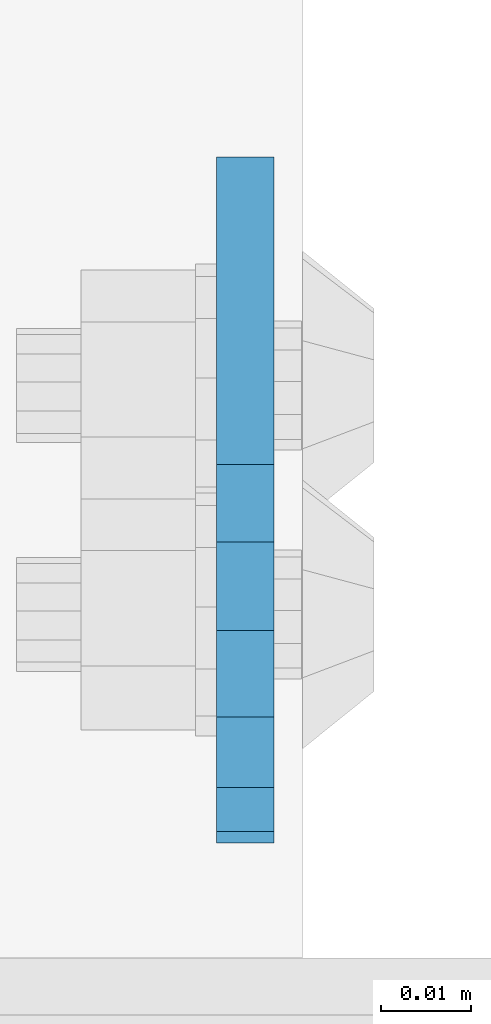
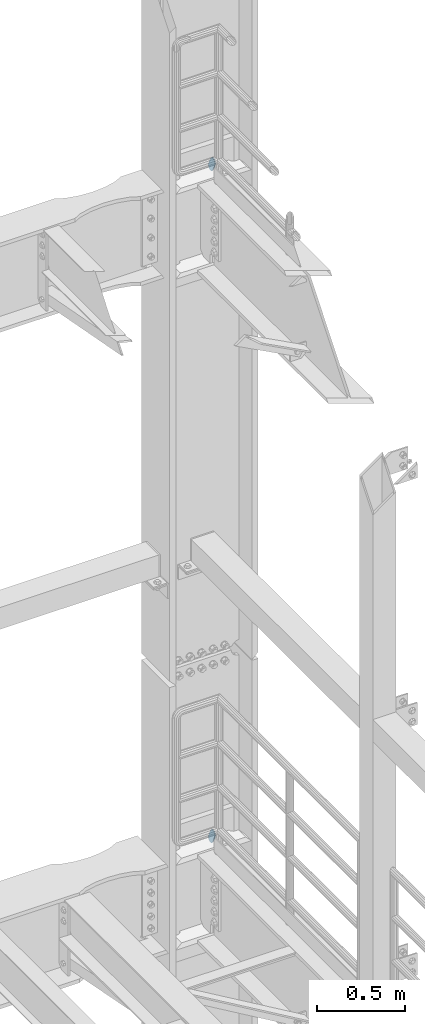
# One storey, part 1836 of 1876: 2 plates, 2 elements without a shape of their own.
"""IFC2X3 building model written with IfcOpenShell, lengths in millimetres."""

from ifc_helpers import new_model, si_unit, frame, origin_with_axes, place, context, subcontext, project, spatial, faceted_brep, material, type_object, element, aggregate, save


model = new_model("IFC2X3")

# Units and contexts
model_context = context("Model", 3, precision=1e-05, world=origin_with_axes())
body_context = subcontext(model_context, "Body", "Model", "MODEL_VIEW")
ifc_project = project(units=[si_unit("LENGTHUNIT", "METRE", prefix="MILLI"), si_unit("AREAUNIT", "SQUARE_METRE"), si_unit("VOLUMEUNIT", "CUBIC_METRE"), si_unit("MASSUNIT", "GRAM", prefix="KILO"), si_unit("TIMEUNIT", "SECOND"), si_unit("PLANEANGLEUNIT", "RADIAN"), si_unit("SOLIDANGLEUNIT", "STERADIAN"), si_unit("THERMODYNAMICTEMPERATUREUNIT", "DEGREE_CELSIUS"), si_unit("LUMINOUSINTENSITYUNIT", "LUMEN")], contexts=[model_context])

# Site, building, storey
site_placement = place(None, origin_with_axes())
site = spatial("IfcSite", under=ifc_project, at=site_placement, CompositionType="ELEMENT")
building_placement = place(site_placement, origin_with_axes())
building = spatial("IfcBuilding", under=site, at=building_placement, Name="Undefined", CompositionType="ELEMENT")
storey_placement = place(building_placement, origin_with_axes())
storey = spatial("IfcBuildingStorey", under=building, at=storey_placement, Name="Undefined", CompositionType="ELEMENT", Elevation=0.0)

# Assembly, plate
assembly_1_placement = place(storey_placement, origin_with_axes())
assembly_1 = element("IfcElementAssembly", 1, at=assembly_1_placement, inside=storey, Name="PLATE", AssemblyPlace="NOTDEFINED", PredefinedType="RIGID_FRAME")
ifc_material = material(Name="STEEL/A36")
plate_type = type_object("IfcPlateType", PredefinedType="NOTDEFINED")
plate_1_placement = place(assembly_1_placement, frame((7905.73879597858, 14070.2592249372, 17725.1776774809), z_axis=(0.0, -0.894427191199917, -0.447213595099956), x_axis=(0.0, 0.447213595099955, -0.894427191199917)))
plate_1 = element("IfcPlate", 2, at=plate_1_placement, type_object=plate_type, material=ifc_material, Name="PLATE", context=body_context, shape_type="Brep", body=[
    faceted_brep([(-8.59611645864788e-07, -3.17499999999654, 25.3999987589127), (1.93345873884391, -3.17499999999382, 35.1201580589886), (1.93345873884391, 3.17500000000564, 35.1201580589886), (-8.59611645864788e-07, 3.17500000000382, 25.3999987589132), (7.43948648259902, -3.17499999999109, 43.3605112870105), (7.43948648259902, 3.17500000000928, 43.3605112870105), (15.6798395242777, -3.17499999998654, 48.8665393096448), (15.6798395242777, 3.17500000001382, 48.8665393096448), (25.3999987589095, -3.17499999998199, 50.7999992370592), (25.3999987589095, 3.17500000001837, 50.7999992370592), (82.196130752618, -3.17499999998381, 50.7999992370605), (82.196130752618, 3.17500000001655, 50.7999992370642), (91.9162897887145, -3.17499999997926, 48.8665393918873), (91.9162897887145, 3.1750000000211, 48.8665393918909), (100.156642725027, -3.17499999997472, 43.3605115909359), (100.156642725027, 3.17500000002565, 43.3605115909395), (105.662670525982, -3.17499999997108, 35.1201586546285), (105.662670525986, 3.17500000002929, 35.1201586546358), (107.596130371159, -3.17499999996744, 25.3999996185757), (107.596130371159, 3.17500000003292, 25.3999996185794), (105.662670525981, -3.17499999996471, 15.6798405824902), (105.662670525981, 3.17500000003565, 15.6798405824939), (100.156642725024, -3.17499999996471, 7.43948764618654), (100.156642725025, 3.17500000003565, 7.43948764619017), (91.9162897887127, -3.17499999996562, 1.93345984522784), (91.9162897887127, 3.17500000003474, 1.93345984523148), (82.196130752618, -3.17499999996835, 4.54747350886464e-11), (82.196130752618, 3.1750000000311, 4.91127138957381e-11), (25.399998758905, -3.17499999999018, -8.64019966684282e-12), (25.399998758905, 3.17500000001019, -8.64019966684282e-12), (15.679839921364, -3.17499999999382, 1.9334597629304), (15.679839921364, 3.17500000000655, 1.9334597629304), (7.43948709043525, -3.17499999999654, 7.43948734220839), (7.43948709043525, 3.17500000000382, 7.43948734220885), (1.93345923228208, -3.17499999999654, 15.6798399868012), (1.93345923228208, 3.17500000000291, 15.6798399868012)], [[[0, 1, 2, 3]], [[1, 4, 5, 2]], [[4, 6, 7, 5]], [[6, 8, 9, 7]], [[8, 10, 11, 9]], [[10, 12, 13, 11]], [[12, 14, 15, 13]], [[14, 16, 17, 15]], [[16, 18, 19, 17]], [[18, 20, 21, 19]], [[20, 22, 23, 21]], [[22, 24, 25, 23]], [[24, 26, 27, 25]], [[26, 28, 29, 27]], [[28, 30, 31, 29]], [[30, 32, 33, 31]], [[32, 34, 35, 33]], [[34, 0, 3, 35]], [[5, 7, 9, 11, 13, 15, 17, 19, 21, 23, 25, 27, 29, 31, 33, 35, 3, 2]], [[34, 32, 30, 28, 26, 24, 22, 20, 18, 16, 14, 12, 10, 8, 6, 4, 1, 0]]]),
])
aggregate(assembly_1, [plate_1])

assembly_2_placement = place(storey_placement, origin_with_axes())
assembly_2 = element("IfcElementAssembly", 3, at=assembly_2_placement, inside=storey, Name="PLATE", AssemblyPlace="NOTDEFINED", PredefinedType="RIGID_FRAME")
plate_2_placement = place(assembly_2_placement, frame((7905.73879597858, 14070.2592249372, 13038.8776774809), z_axis=(0.0, -0.894427191199917, -0.447213595099956), x_axis=(0.0, 0.447213595099955, -0.894427191199917)))
plate_2 = element("IfcPlate", 4, at=plate_2_placement, type_object=plate_type, material=ifc_material, Name="PLATE", context=body_context, shape_type="Brep", body=[
    faceted_brep([(-8.59611645864788e-07, -3.17499999999654, 25.3999987589127), (1.93345873884391, -3.17499999999382, 35.1201580589886), (1.93345873884391, 3.17500000000564, 35.1201580589886), (-8.59611645864788e-07, 3.17500000000382, 25.3999987589132), (7.43948648259902, -3.17499999999109, 43.3605112870105), (7.43948648259902, 3.17500000000928, 43.3605112870105), (15.6798395242777, -3.17499999998654, 48.8665393096448), (15.6798395242777, 3.17500000001382, 48.8665393096448), (25.3999987589095, -3.17499999998199, 50.7999992370592), (25.3999987589095, 3.17500000001837, 50.7999992370592), (82.196130752618, -3.17499999998381, 50.7999992370605), (82.196130752618, 3.17500000001655, 50.7999992370642), (91.9162897887145, -3.17499999997926, 48.8665393918873), (91.9162897887145, 3.1750000000211, 48.8665393918909), (100.156642725027, -3.17499999997472, 43.3605115909359), (100.156642725027, 3.17500000002565, 43.3605115909395), (105.662670525982, -3.17499999997108, 35.1201586546285), (105.662670525986, 3.17500000002929, 35.1201586546358), (107.596130371159, -3.17499999996744, 25.3999996185757), (107.596130371159, 3.17500000003292, 25.3999996185794), (105.662670525981, -3.17499999996471, 15.6798405824902), (105.662670525981, 3.17500000003565, 15.6798405824939), (100.156642725024, -3.17499999996471, 7.43948764618654), (100.156642725025, 3.17500000003565, 7.43948764619017), (91.9162897887127, -3.17499999996562, 1.93345984522784), (91.9162897887127, 3.17500000003474, 1.93345984523148), (82.196130752618, -3.17499999996835, 4.54747350886464e-11), (82.196130752618, 3.1750000000311, 4.91127138957381e-11), (25.399998758905, -3.17499999999018, -8.64019966684282e-12), (25.399998758905, 3.17500000001019, -8.64019966684282e-12), (15.679839921364, -3.17499999999382, 1.9334597629304), (15.679839921364, 3.17500000000655, 1.9334597629304), (7.43948709043525, -3.17499999999654, 7.43948734220839), (7.43948709043525, 3.17500000000382, 7.43948734220885), (1.93345923228208, -3.17499999999654, 15.6798399868012), (1.93345923228208, 3.17500000000291, 15.6798399868012)], [[[0, 1, 2, 3]], [[1, 4, 5, 2]], [[4, 6, 7, 5]], [[6, 8, 9, 7]], [[8, 10, 11, 9]], [[10, 12, 13, 11]], [[12, 14, 15, 13]], [[14, 16, 17, 15]], [[16, 18, 19, 17]], [[18, 20, 21, 19]], [[20, 22, 23, 21]], [[22, 24, 25, 23]], [[24, 26, 27, 25]], [[26, 28, 29, 27]], [[28, 30, 31, 29]], [[30, 32, 33, 31]], [[32, 34, 35, 33]], [[34, 0, 3, 35]], [[5, 7, 9, 11, 13, 15, 17, 19, 21, 23, 25, 27, 29, 31, 33, 35, 3, 2]], [[34, 32, 30, 28, 26, 24, 22, 20, 18, 16, 14, 12, 10, 8, 6, 4, 1, 0]]]),
])
aggregate(assembly_2, [plate_2])

save(model, "model.ifc")
